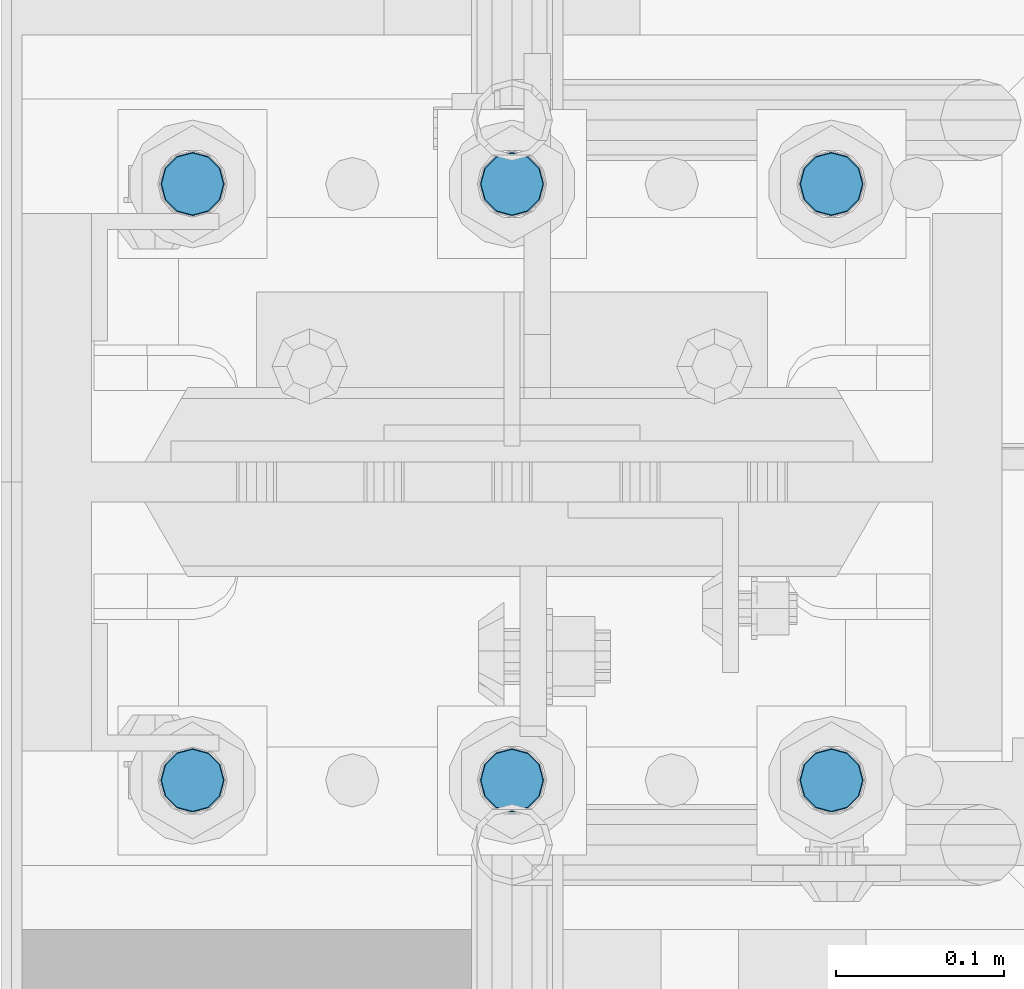
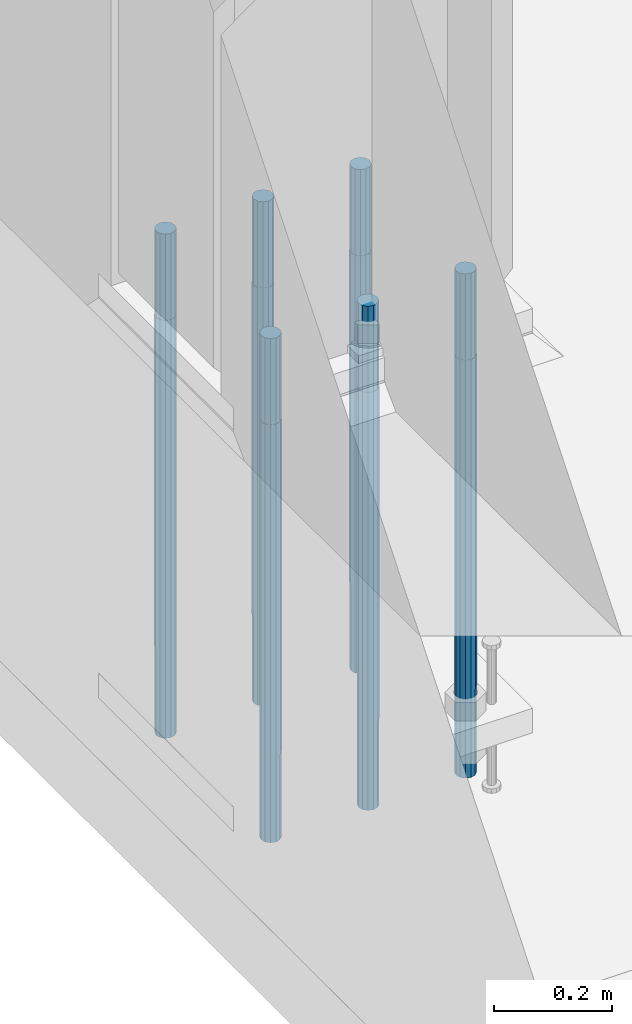
# One storey, part 599 of 1876: 6 columns, 1 element without a shape of its own.
"""IFC2X3 building model written with IfcOpenShell, lengths in millimetres."""

from ifc_helpers import new_model, si_unit, frame, origin_with_axes, place, context, subcontext, project, spatial, faceted_brep, material, type_object, element, aggregate, save


model = new_model("IFC2X3")

# Units and contexts
model_context = context("Model", 3, precision=1e-05, world=origin_with_axes())
body_context = subcontext(model_context, "Body", "Model", "MODEL_VIEW")
ifc_project = project(units=[si_unit("LENGTHUNIT", "METRE", prefix="MILLI"), si_unit("AREAUNIT", "SQUARE_METRE"), si_unit("VOLUMEUNIT", "CUBIC_METRE"), si_unit("MASSUNIT", "GRAM", prefix="KILO"), si_unit("TIMEUNIT", "SECOND"), si_unit("PLANEANGLEUNIT", "RADIAN"), si_unit("SOLIDANGLEUNIT", "STERADIAN"), si_unit("THERMODYNAMICTEMPERATUREUNIT", "DEGREE_CELSIUS"), si_unit("LUMINOUSINTENSITYUNIT", "LUMEN")], contexts=[model_context])

# Site, building, storey
site_placement = place(None, origin_with_axes())
site = spatial("IfcSite", under=ifc_project, at=site_placement, CompositionType="ELEMENT")
building_placement = place(site_placement, origin_with_axes())
building = spatial("IfcBuilding", under=site, at=building_placement, Name="Undefined", CompositionType="ELEMENT")
storey_placement = place(building_placement, origin_with_axes())
storey = spatial("IfcBuildingStorey", under=building, at=storey_placement, Name="Undefined", CompositionType="ELEMENT", Elevation=0.0)

# Assembly, columns
assembly_placement = place(storey_placement, origin_with_axes())
assembly = element("IfcElementAssembly", 1, at=assembly_placement, inside=storey, Name="TEMPLATE", AssemblyPlace="NOTDEFINED", PredefinedType="RIGID_FRAME")
ifc_material = material(Name="STEEL/F1554-GR.105")
column_type = type_object("IfcColumnType", PredefinedType="NOTDEFINED")
column_1_placement = place(assembly_placement, frame((190.5, -4749.8, 0.0), z_axis=(1.0, 0.0, 0.0), x_axis=(0.0, 0.0, -1.0)))
column_1 = element("IfcColumn", 2, at=column_1_placement, type_object=column_type, material=ifc_material, Name="ANCHOR_BOLTS", context=body_context, shape_type="Brep", body=[
    faceted_brep([(-177.8, -16.0214699700118, 9.25), (-177.8, -9.25, 16.0214699700121), (-177.8, 0.0, 18.5), (-177.8, 9.25, 16.0214699700121), (-177.8, 16.0214699700118, 9.25), (-177.8, 18.5, 0.0), (-177.8, 16.0214699700118, -9.25), (-177.8, 9.25, -16.0214699700121), (-177.8, 0.0, -18.5), (-177.8, -9.25, -16.0214699700121), (-177.8, -16.0214699700118, -9.25), (-177.8, -18.5, 0.0), (0.0, 18.5, 0.0), (0.0, 16.0214699700118, -9.25), (0.0, 9.25, -16.0214699700121), (0.0, 0.0, -18.5), (0.0, -9.25, -16.0214699700121), (0.0, -16.0214699700118, -9.25), (0.0, -18.5, 0.0), (0.0, -16.0214699700118, 9.25), (0.0, -9.25, 16.0214699700121), (0.0, 0.0, 18.5), (0.0, 9.25, 16.0214699700121), (0.0, 16.0214699700118, 9.25), (0.0, -16.4977839420935, 9.52500000000146), (0.0, -9.52500000000009, 16.4977839420935), (0.0, 0.0, 19.0499999999993), (0.0, 9.52500000000009, 16.4977839420935), (0.0, 16.4977839420935, 9.52500000000146), (-9.09494701772928e-13, 19.05, -1.81898940354586e-12), (0.0, 16.4977839420935, -9.52500000000146), (0.0, 9.52500000000009, -16.4977839420935), (0.0, 0.0, -19.05), (0.0, -9.52500000000009, -16.4977839420935), (0.0, -16.4977839420935, -9.52500000000146), (0.0, -19.0500000000002, 0.0), (685.799999999999, -19.05, 0.0), (685.799999999999, -16.4977839420936, 9.52500000000146), (685.799999999999, -9.52499999999998, 16.4977839420935), (685.799999999999, 0.0, 19.0499999999993), (685.799999999999, 9.52499999999998, 16.4977839420935), (685.799999999999, 16.4977839420936, 9.52500000000146), (685.799999999999, 19.05, 0.0), (685.799999999999, 16.4977839420936, -9.52500000000146), (685.799999999999, 9.52500000000003, -16.4977839420935), (685.799999999999, 0.0, -19.0499999999993), (685.799999999999, -9.52499999999998, -16.4977839420935), (685.799999999999, -16.4977839420936, -9.52500000000146), (685.8, -9.25, 16.0214699700121), (685.8, 0.0, 18.5), (685.8, 9.25, 16.0214699700121), (685.8, 16.0214699700118, 9.25), (685.8, 18.5, 0.0), (685.8, 16.0214699700118, -9.25), (685.8, 9.25, -16.0214699700121), (685.8, 0.0, -18.5), (685.8, -9.25, -16.0214699700121), (685.8, -16.0214699700118, -9.25), (685.8, -18.5, 0.0), (685.8, -16.0214699700118, 9.25), (863.6, -9.25, -16.0214699700121), (863.6, 0.0, -18.5), (863.6, 9.25, -16.0214699700121), (863.6, 16.0214699700118, -9.25), (863.6, 18.5, 0.0), (863.6, 16.0214699700118, 9.25), (863.6, 9.25, 16.0214699700121), (863.6, 0.0, 18.5), (863.6, -9.25, 16.0214699700121), (863.6, -16.0214699700118, 9.25), (863.6, -18.5, 0.0), (863.6, -16.0214699700118, -9.25)], [[[0, 1, 2, 3, 4, 5, 6, 7, 8, 9, 10, 11]], [[6, 5, 12, 13]], [[7, 6, 13, 14]], [[8, 7, 14, 15]], [[9, 8, 15, 16]], [[10, 9, 16, 17]], [[11, 10, 17, 18]], [[0, 11, 18, 19]], [[1, 0, 19, 20]], [[2, 1, 20, 21]], [[3, 2, 21, 22]], [[4, 3, 22, 23]], [[5, 4, 23, 12]], [[24, 25, 26, 27, 28, 29, 30, 31, 32, 33, 34, 35], [22, 21, 20, 19, 18, 17, 16, 15, 14, 13, 12, 23]], [[24, 35, 36, 37]], [[25, 24, 37, 38]], [[26, 25, 38, 39]], [[27, 26, 39, 40]], [[28, 27, 40, 41]], [[29, 28, 41, 42]], [[30, 29, 42, 43]], [[31, 30, 43, 44]], [[32, 31, 44, 45]], [[33, 32, 45, 46]], [[34, 33, 46, 47]], [[35, 34, 47, 36]], [[46, 45, 44, 43, 42, 41, 40, 39, 38, 37, 36, 47], [48, 49, 50, 51, 52, 53, 54, 55, 56, 57, 58, 59]], [[60, 61, 62, 63, 64, 65, 66, 67, 68, 69, 70, 71]], [[68, 67, 49, 48]], [[69, 68, 48, 59]], [[70, 69, 59, 58]], [[71, 70, 58, 57]], [[60, 71, 57, 56]], [[61, 60, 56, 55]], [[62, 61, 55, 54]], [[63, 62, 54, 53]], [[64, 63, 53, 52]], [[65, 64, 52, 51]], [[66, 65, 51, 50]], [[67, 66, 50, 49]]]),
])
column_2_placement = place(assembly_placement, frame((190.5, -4394.2, 0.0), z_axis=(-1.0, 0.0, 0.0), x_axis=(0.0, 0.0, -1.0)))
column_2 = element("IfcColumn", 3, at=column_2_placement, type_object=column_type, material=ifc_material, Name="ANCHOR_BOLTS", context=body_context, shape_type="Brep", body=[
    faceted_brep([(-177.8, -16.0214699700118, 9.25), (-177.8, -9.25, 16.0214699700121), (-177.8, 0.0, 18.5), (-177.8, 9.25, 16.0214699700121), (-177.8, 16.0214699700118, 9.25), (-177.8, 18.5, 0.0), (-177.8, 16.0214699700118, -9.25), (-177.8, 9.25, -16.0214699700121), (-177.8, 0.0, -18.5), (-177.8, -9.25, -16.0214699700121), (-177.8, -16.0214699700118, -9.25), (-177.8, -18.5, 0.0), (0.0, 18.5, 0.0), (0.0, 16.0214699700118, -9.25), (0.0, 9.25, -16.0214699700121), (0.0, 0.0, -18.5), (0.0, -9.25, -16.0214699700121), (0.0, -16.0214699700118, -9.25), (0.0, -18.5, 0.0), (0.0, -16.0214699700118, 9.25), (0.0, -9.25, 16.0214699700121), (0.0, 0.0, 18.5), (0.0, 9.25, 16.0214699700121), (0.0, 16.0214699700118, 9.25), (0.0, -16.4977839420935, 9.52500000000146), (0.0, -9.52500000000009, 16.4977839420935), (0.0, 0.0, 19.0499999999993), (0.0, 9.52500000000009, 16.4977839420935), (0.0, 16.4977839420935, 9.52500000000146), (-9.09494701772928e-13, 19.05, -1.81898940354586e-12), (0.0, 16.4977839420935, -9.52500000000146), (0.0, 9.52500000000009, -16.4977839420935), (0.0, 0.0, -19.05), (0.0, -9.52500000000009, -16.4977839420935), (0.0, -16.4977839420935, -9.52500000000146), (0.0, -19.0500000000002, 0.0), (685.799999999999, -19.05, 0.0), (685.799999999999, -16.4977839420936, 9.52500000000146), (685.799999999999, -9.52499999999998, 16.4977839420935), (685.799999999999, 0.0, 19.0499999999993), (685.799999999999, 9.52499999999998, 16.4977839420935), (685.799999999999, 16.4977839420936, 9.52500000000146), (685.799999999999, 19.05, 0.0), (685.799999999999, 16.4977839420936, -9.52500000000146), (685.799999999999, 9.52500000000003, -16.4977839420935), (685.799999999999, 0.0, -19.0499999999993), (685.799999999999, -9.52499999999998, -16.4977839420935), (685.799999999999, -16.4977839420936, -9.52500000000146), (685.8, -9.25, 16.0214699700121), (685.8, 0.0, 18.5), (685.8, 9.25, 16.0214699700121), (685.8, 16.0214699700118, 9.25), (685.8, 18.5, 0.0), (685.8, 16.0214699700118, -9.25), (685.8, 9.25, -16.0214699700121), (685.8, 0.0, -18.5), (685.8, -9.25, -16.0214699700121), (685.8, -16.0214699700118, -9.25), (685.8, -18.5, 0.0), (685.8, -16.0214699700118, 9.25), (863.6, -9.25, -16.0214699700121), (863.6, 0.0, -18.5), (863.6, 9.25, -16.0214699700121), (863.6, 16.0214699700118, -9.25), (863.6, 18.5, 0.0), (863.6, 16.0214699700118, 9.25), (863.6, 9.25, 16.0214699700121), (863.6, 0.0, 18.5), (863.6, -9.25, 16.0214699700121), (863.6, -16.0214699700118, 9.25), (863.6, -18.5, 0.0), (863.6, -16.0214699700118, -9.25)], [[[0, 1, 2, 3, 4, 5, 6, 7, 8, 9, 10, 11]], [[6, 5, 12, 13]], [[7, 6, 13, 14]], [[8, 7, 14, 15]], [[9, 8, 15, 16]], [[10, 9, 16, 17]], [[11, 10, 17, 18]], [[0, 11, 18, 19]], [[1, 0, 19, 20]], [[2, 1, 20, 21]], [[3, 2, 21, 22]], [[4, 3, 22, 23]], [[5, 4, 23, 12]], [[24, 25, 26, 27, 28, 29, 30, 31, 32, 33, 34, 35], [22, 21, 20, 19, 18, 17, 16, 15, 14, 13, 12, 23]], [[24, 35, 36, 37]], [[25, 24, 37, 38]], [[26, 25, 38, 39]], [[27, 26, 39, 40]], [[28, 27, 40, 41]], [[29, 28, 41, 42]], [[30, 29, 42, 43]], [[31, 30, 43, 44]], [[32, 31, 44, 45]], [[33, 32, 45, 46]], [[34, 33, 46, 47]], [[35, 34, 47, 36]], [[46, 45, 44, 43, 42, 41, 40, 39, 38, 37, 36, 47], [48, 49, 50, 51, 52, 53, 54, 55, 56, 57, 58, 59]], [[60, 61, 62, 63, 64, 65, 66, 67, 68, 69, 70, 71]], [[68, 67, 49, 48]], [[69, 68, 48, 59]], [[70, 69, 59, 58]], [[71, 70, 58, 57]], [[60, 71, 57, 56]], [[61, 60, 56, 55]], [[62, 61, 55, 54]], [[63, 62, 54, 53]], [[64, 63, 53, 52]], [[65, 64, 52, 51]], [[66, 65, 51, 50]], [[67, 66, 50, 49]]]),
])
column_3_placement = place(assembly_placement, frame((-2.8421709430404e-14, -4749.8, 0.0), z_axis=(1.0, 0.0, 0.0), x_axis=(0.0, 0.0, -1.0)))
column_3 = element("IfcColumn", 4, at=column_3_placement, type_object=column_type, material=ifc_material, Name="ANCHOR_BOLTS", context=body_context, shape_type="Brep", body=[
    faceted_brep([(-177.8, -16.0214699700118, 9.25), (-177.8, -9.25, 16.0214699700121), (-177.8, 0.0, 18.5), (-177.8, 9.25, 16.0214699700121), (-177.8, 16.0214699700118, 9.25), (-177.8, 18.5, 0.0), (-177.8, 16.0214699700118, -9.25), (-177.8, 9.25, -16.0214699700121), (-177.8, 0.0, -18.5), (-177.8, -9.25, -16.0214699700121), (-177.8, -16.0214699700118, -9.25), (-177.8, -18.5, 0.0), (0.0, 18.5, 0.0), (0.0, 16.0214699700118, -9.25), (0.0, 9.25, -16.0214699700121), (0.0, 0.0, -18.5), (0.0, -9.25, -16.0214699700121), (0.0, -16.0214699700118, -9.25), (0.0, -18.5, 0.0), (0.0, -16.0214699700118, 9.25), (0.0, -9.25, 16.0214699700121), (0.0, 0.0, 18.5), (0.0, 9.25, 16.0214699700121), (0.0, 16.0214699700118, 9.25), (0.0, -16.4977839420935, 9.52500000000146), (0.0, -9.52500000000009, 16.4977839420935), (0.0, 0.0, 19.0499999999993), (0.0, 9.52500000000009, 16.4977839420935), (0.0, 16.4977839420935, 9.52500000000146), (-9.09494701772928e-13, 19.05, -1.81898940354586e-12), (0.0, 16.4977839420935, -9.52500000000146), (0.0, 9.52500000000009, -16.4977839420935), (0.0, 0.0, -19.05), (0.0, -9.52500000000009, -16.4977839420935), (0.0, -16.4977839420935, -9.52500000000146), (0.0, -19.0500000000002, 0.0), (685.799999999999, -19.05, 0.0), (685.799999999999, -16.4977839420936, 9.52500000000146), (685.799999999999, -9.52499999999998, 16.4977839420935), (685.799999999999, 0.0, 19.0499999999993), (685.799999999999, 9.52499999999998, 16.4977839420935), (685.799999999999, 16.4977839420936, 9.52500000000146), (685.799999999999, 19.05, 0.0), (685.799999999999, 16.4977839420936, -9.52500000000146), (685.799999999999, 9.52500000000003, -16.4977839420935), (685.799999999999, 0.0, -19.0499999999993), (685.799999999999, -9.52499999999998, -16.4977839420935), (685.799999999999, -16.4977839420936, -9.52500000000146), (685.8, -9.25, 16.0214699700121), (685.8, 0.0, 18.5), (685.8, 9.25, 16.0214699700121), (685.8, 16.0214699700118, 9.25), (685.8, 18.5, 0.0), (685.8, 16.0214699700118, -9.25), (685.8, 9.25, -16.0214699700121), (685.8, 0.0, -18.5), (685.8, -9.25, -16.0214699700121), (685.8, -16.0214699700118, -9.25), (685.8, -18.5, 0.0), (685.8, -16.0214699700118, 9.25), (863.6, -9.25, -16.0214699700121), (863.6, 0.0, -18.5), (863.6, 9.25, -16.0214699700121), (863.6, 16.0214699700118, -9.25), (863.6, 18.5, 0.0), (863.6, 16.0214699700118, 9.25), (863.6, 9.25, 16.0214699700121), (863.6, 0.0, 18.5), (863.6, -9.25, 16.0214699700121), (863.6, -16.0214699700118, 9.25), (863.6, -18.5, 0.0), (863.6, -16.0214699700118, -9.25)], [[[0, 1, 2, 3, 4, 5, 6, 7, 8, 9, 10, 11]], [[6, 5, 12, 13]], [[7, 6, 13, 14]], [[8, 7, 14, 15]], [[9, 8, 15, 16]], [[10, 9, 16, 17]], [[11, 10, 17, 18]], [[0, 11, 18, 19]], [[1, 0, 19, 20]], [[2, 1, 20, 21]], [[3, 2, 21, 22]], [[4, 3, 22, 23]], [[5, 4, 23, 12]], [[24, 25, 26, 27, 28, 29, 30, 31, 32, 33, 34, 35], [22, 21, 20, 19, 18, 17, 16, 15, 14, 13, 12, 23]], [[24, 35, 36, 37]], [[25, 24, 37, 38]], [[26, 25, 38, 39]], [[27, 26, 39, 40]], [[28, 27, 40, 41]], [[29, 28, 41, 42]], [[30, 29, 42, 43]], [[31, 30, 43, 44]], [[32, 31, 44, 45]], [[33, 32, 45, 46]], [[34, 33, 46, 47]], [[35, 34, 47, 36]], [[46, 45, 44, 43, 42, 41, 40, 39, 38, 37, 36, 47], [48, 49, 50, 51, 52, 53, 54, 55, 56, 57, 58, 59]], [[60, 61, 62, 63, 64, 65, 66, 67, 68, 69, 70, 71]], [[68, 67, 49, 48]], [[69, 68, 48, 59]], [[70, 69, 59, 58]], [[71, 70, 58, 57]], [[60, 71, 57, 56]], [[61, 60, 56, 55]], [[62, 61, 55, 54]], [[63, 62, 54, 53]], [[64, 63, 53, 52]], [[65, 64, 52, 51]], [[66, 65, 51, 50]], [[67, 66, 50, 49]]]),
])
column_4_placement = place(assembly_placement, frame((-2.8421709430404e-14, -4394.2, 0.0), z_axis=(-1.0, 0.0, 0.0), x_axis=(0.0, 0.0, -1.0)))
column_4 = element("IfcColumn", 5, at=column_4_placement, type_object=column_type, material=ifc_material, Name="ANCHOR_BOLTS", context=body_context, shape_type="Brep", body=[
    faceted_brep([(-177.8, -16.0214699700118, 9.25), (-177.8, -9.25, 16.0214699700121), (-177.8, 0.0, 18.5), (-177.8, 9.25, 16.0214699700121), (-177.8, 16.0214699700118, 9.25), (-177.8, 18.5, 0.0), (-177.8, 16.0214699700118, -9.25), (-177.8, 9.25, -16.0214699700121), (-177.8, 0.0, -18.5), (-177.8, -9.25, -16.0214699700121), (-177.8, -16.0214699700118, -9.25), (-177.8, -18.5, 0.0), (0.0, 18.5, 0.0), (0.0, 16.0214699700118, -9.25), (0.0, 9.25, -16.0214699700121), (0.0, 0.0, -18.5), (0.0, -9.25, -16.0214699700121), (0.0, -16.0214699700118, -9.25), (0.0, -18.5, 0.0), (0.0, -16.0214699700118, 9.25), (0.0, -9.25, 16.0214699700121), (0.0, 0.0, 18.5), (0.0, 9.25, 16.0214699700121), (0.0, 16.0214699700118, 9.25), (0.0, -16.4977839420935, 9.52500000000146), (0.0, -9.52500000000009, 16.4977839420935), (0.0, 0.0, 19.0499999999993), (0.0, 9.52500000000009, 16.4977839420935), (0.0, 16.4977839420935, 9.52500000000146), (-9.09494701772928e-13, 19.05, -1.81898940354586e-12), (0.0, 16.4977839420935, -9.52500000000146), (0.0, 9.52500000000009, -16.4977839420935), (0.0, 0.0, -19.05), (0.0, -9.52500000000009, -16.4977839420935), (0.0, -16.4977839420935, -9.52500000000146), (0.0, -19.0500000000002, 0.0), (685.799999999999, -19.05, 0.0), (685.799999999999, -16.4977839420936, 9.52500000000146), (685.799999999999, -9.52499999999998, 16.4977839420935), (685.799999999999, 0.0, 19.0499999999993), (685.799999999999, 9.52499999999998, 16.4977839420935), (685.799999999999, 16.4977839420936, 9.52500000000146), (685.799999999999, 19.05, 0.0), (685.799999999999, 16.4977839420936, -9.52500000000146), (685.799999999999, 9.52500000000003, -16.4977839420935), (685.799999999999, 0.0, -19.0499999999993), (685.799999999999, -9.52499999999998, -16.4977839420935), (685.799999999999, -16.4977839420936, -9.52500000000146), (685.8, -9.25, 16.0214699700121), (685.8, 0.0, 18.5), (685.8, 9.25, 16.0214699700121), (685.8, 16.0214699700118, 9.25), (685.8, 18.5, 0.0), (685.8, 16.0214699700118, -9.25), (685.8, 9.25, -16.0214699700121), (685.8, 0.0, -18.5), (685.8, -9.25, -16.0214699700121), (685.8, -16.0214699700118, -9.25), (685.8, -18.5, 0.0), (685.8, -16.0214699700118, 9.25), (863.6, -9.25, -16.0214699700121), (863.6, 0.0, -18.5), (863.6, 9.25, -16.0214699700121), (863.6, 16.0214699700118, -9.25), (863.6, 18.5, 0.0), (863.6, 16.0214699700118, 9.25), (863.6, 9.25, 16.0214699700121), (863.6, 0.0, 18.5), (863.6, -9.25, 16.0214699700121), (863.6, -16.0214699700118, 9.25), (863.6, -18.5, 0.0), (863.6, -16.0214699700118, -9.25)], [[[0, 1, 2, 3, 4, 5, 6, 7, 8, 9, 10, 11]], [[6, 5, 12, 13]], [[7, 6, 13, 14]], [[8, 7, 14, 15]], [[9, 8, 15, 16]], [[10, 9, 16, 17]], [[11, 10, 17, 18]], [[0, 11, 18, 19]], [[1, 0, 19, 20]], [[2, 1, 20, 21]], [[3, 2, 21, 22]], [[4, 3, 22, 23]], [[5, 4, 23, 12]], [[24, 25, 26, 27, 28, 29, 30, 31, 32, 33, 34, 35], [22, 21, 20, 19, 18, 17, 16, 15, 14, 13, 12, 23]], [[24, 35, 36, 37]], [[25, 24, 37, 38]], [[26, 25, 38, 39]], [[27, 26, 39, 40]], [[28, 27, 40, 41]], [[29, 28, 41, 42]], [[30, 29, 42, 43]], [[31, 30, 43, 44]], [[32, 31, 44, 45]], [[33, 32, 45, 46]], [[34, 33, 46, 47]], [[35, 34, 47, 36]], [[46, 45, 44, 43, 42, 41, 40, 39, 38, 37, 36, 47], [48, 49, 50, 51, 52, 53, 54, 55, 56, 57, 58, 59]], [[60, 61, 62, 63, 64, 65, 66, 67, 68, 69, 70, 71]], [[68, 67, 49, 48]], [[69, 68, 48, 59]], [[70, 69, 59, 58]], [[71, 70, 58, 57]], [[60, 71, 57, 56]], [[61, 60, 56, 55]], [[62, 61, 55, 54]], [[63, 62, 54, 53]], [[64, 63, 53, 52]], [[65, 64, 52, 51]], [[66, 65, 51, 50]], [[67, 66, 50, 49]]]),
])
column_5_placement = place(assembly_placement, frame((-190.5, -4749.8, 0.0), z_axis=(1.0, 0.0, 0.0), x_axis=(0.0, 0.0, -1.0)))
column_5 = element("IfcColumn", 6, at=column_5_placement, type_object=column_type, material=ifc_material, Name="ANCHOR_BOLTS", context=body_context, shape_type="Brep", body=[
    faceted_brep([(-177.8, -16.0214699700118, 9.25), (-177.8, -9.25, 16.0214699700121), (-177.8, 0.0, 18.5), (-177.8, 9.25, 16.0214699700121), (-177.8, 16.0214699700118, 9.25), (-177.8, 18.5, 0.0), (-177.8, 16.0214699700118, -9.25), (-177.8, 9.25, -16.0214699700121), (-177.8, 0.0, -18.5), (-177.8, -9.25, -16.0214699700121), (-177.8, -16.0214699700118, -9.25), (-177.8, -18.5, 0.0), (0.0, 18.5, 0.0), (0.0, 16.0214699700118, -9.25), (0.0, 9.25, -16.0214699700121), (0.0, 0.0, -18.5), (0.0, -9.25, -16.0214699700121), (0.0, -16.0214699700118, -9.25), (0.0, -18.5, 0.0), (0.0, -16.0214699700118, 9.25), (0.0, -9.25, 16.0214699700121), (0.0, 0.0, 18.5), (0.0, 9.25, 16.0214699700121), (0.0, 16.0214699700118, 9.25), (0.0, -16.4977839420935, 9.52500000000146), (0.0, -9.52500000000009, 16.4977839420935), (0.0, 0.0, 19.0499999999993), (0.0, 9.52500000000009, 16.4977839420935), (0.0, 16.4977839420935, 9.52500000000146), (-9.09494701772928e-13, 19.05, -1.81898940354586e-12), (0.0, 16.4977839420935, -9.52500000000146), (0.0, 9.52500000000009, -16.4977839420935), (0.0, 0.0, -19.05), (0.0, -9.52500000000009, -16.4977839420935), (0.0, -16.4977839420935, -9.52500000000146), (0.0, -19.0500000000002, 0.0), (685.799999999999, -19.05, 0.0), (685.799999999999, -16.4977839420936, 9.52500000000146), (685.799999999999, -9.52499999999998, 16.4977839420935), (685.799999999999, 0.0, 19.0499999999993), (685.799999999999, 9.52499999999998, 16.4977839420935), (685.799999999999, 16.4977839420936, 9.52500000000146), (685.799999999999, 19.05, 0.0), (685.799999999999, 16.4977839420936, -9.52500000000146), (685.799999999999, 9.52500000000003, -16.4977839420935), (685.799999999999, 0.0, -19.0499999999993), (685.799999999999, -9.52499999999998, -16.4977839420935), (685.799999999999, -16.4977839420936, -9.52500000000146), (685.8, -9.25, 16.0214699700121), (685.8, 0.0, 18.5), (685.8, 9.25, 16.0214699700121), (685.8, 16.0214699700118, 9.25), (685.8, 18.5, 0.0), (685.8, 16.0214699700118, -9.25), (685.8, 9.25, -16.0214699700121), (685.8, 0.0, -18.5), (685.8, -9.25, -16.0214699700121), (685.8, -16.0214699700118, -9.25), (685.8, -18.5, 0.0), (685.8, -16.0214699700118, 9.25), (863.6, -9.25, -16.0214699700121), (863.6, 0.0, -18.5), (863.6, 9.25, -16.0214699700121), (863.6, 16.0214699700118, -9.25), (863.6, 18.5, 0.0), (863.6, 16.0214699700118, 9.25), (863.6, 9.25, 16.0214699700121), (863.6, 0.0, 18.5), (863.6, -9.25, 16.0214699700121), (863.6, -16.0214699700118, 9.25), (863.6, -18.5, 0.0), (863.6, -16.0214699700118, -9.25)], [[[0, 1, 2, 3, 4, 5, 6, 7, 8, 9, 10, 11]], [[6, 5, 12, 13]], [[7, 6, 13, 14]], [[8, 7, 14, 15]], [[9, 8, 15, 16]], [[10, 9, 16, 17]], [[11, 10, 17, 18]], [[0, 11, 18, 19]], [[1, 0, 19, 20]], [[2, 1, 20, 21]], [[3, 2, 21, 22]], [[4, 3, 22, 23]], [[5, 4, 23, 12]], [[24, 25, 26, 27, 28, 29, 30, 31, 32, 33, 34, 35], [22, 21, 20, 19, 18, 17, 16, 15, 14, 13, 12, 23]], [[24, 35, 36, 37]], [[25, 24, 37, 38]], [[26, 25, 38, 39]], [[27, 26, 39, 40]], [[28, 27, 40, 41]], [[29, 28, 41, 42]], [[30, 29, 42, 43]], [[31, 30, 43, 44]], [[32, 31, 44, 45]], [[33, 32, 45, 46]], [[34, 33, 46, 47]], [[35, 34, 47, 36]], [[46, 45, 44, 43, 42, 41, 40, 39, 38, 37, 36, 47], [48, 49, 50, 51, 52, 53, 54, 55, 56, 57, 58, 59]], [[60, 61, 62, 63, 64, 65, 66, 67, 68, 69, 70, 71]], [[68, 67, 49, 48]], [[69, 68, 48, 59]], [[70, 69, 59, 58]], [[71, 70, 58, 57]], [[60, 71, 57, 56]], [[61, 60, 56, 55]], [[62, 61, 55, 54]], [[63, 62, 54, 53]], [[64, 63, 53, 52]], [[65, 64, 52, 51]], [[66, 65, 51, 50]], [[67, 66, 50, 49]]]),
])
column_6_placement = place(assembly_placement, frame((-190.5, -4394.2, 0.0), z_axis=(-1.0, 0.0, 0.0), x_axis=(0.0, 0.0, -1.0)))
column_6 = element("IfcColumn", 7, at=column_6_placement, type_object=column_type, material=ifc_material, Name="ANCHOR_BOLTS", context=body_context, shape_type="Brep", body=[
    faceted_brep([(-177.8, -16.0214699700118, 9.25), (-177.8, -9.25, 16.0214699700121), (-177.8, 0.0, 18.5), (-177.8, 9.25, 16.0214699700121), (-177.8, 16.0214699700118, 9.25), (-177.8, 18.5, 0.0), (-177.8, 16.0214699700118, -9.25), (-177.8, 9.25, -16.0214699700121), (-177.8, 0.0, -18.5), (-177.8, -9.25, -16.0214699700121), (-177.8, -16.0214699700118, -9.25), (-177.8, -18.5, 0.0), (0.0, 18.5, 0.0), (0.0, 16.0214699700118, -9.25), (0.0, 9.25, -16.0214699700121), (0.0, 0.0, -18.5), (0.0, -9.25, -16.0214699700121), (0.0, -16.0214699700118, -9.25), (0.0, -18.5, 0.0), (0.0, -16.0214699700118, 9.25), (0.0, -9.25, 16.0214699700121), (0.0, 0.0, 18.5), (0.0, 9.25, 16.0214699700121), (0.0, 16.0214699700118, 9.25), (0.0, -16.4977839420935, 9.52500000000146), (0.0, -9.52500000000009, 16.4977839420935), (0.0, 0.0, 19.0499999999993), (0.0, 9.52500000000009, 16.4977839420935), (0.0, 16.4977839420935, 9.52500000000146), (-9.09494701772928e-13, 19.05, -1.81898940354586e-12), (0.0, 16.4977839420935, -9.52500000000146), (0.0, 9.52500000000009, -16.4977839420935), (0.0, 0.0, -19.05), (0.0, -9.52500000000009, -16.4977839420935), (0.0, -16.4977839420935, -9.52500000000146), (0.0, -19.0500000000002, 0.0), (685.799999999999, -19.05, 0.0), (685.799999999999, -16.4977839420936, 9.52500000000146), (685.799999999999, -9.52499999999998, 16.4977839420935), (685.799999999999, 0.0, 19.0499999999993), (685.799999999999, 9.52499999999998, 16.4977839420935), (685.799999999999, 16.4977839420936, 9.52500000000146), (685.799999999999, 19.05, 0.0), (685.799999999999, 16.4977839420936, -9.52500000000146), (685.799999999999, 9.52500000000003, -16.4977839420935), (685.799999999999, 0.0, -19.0499999999993), (685.799999999999, -9.52499999999998, -16.4977839420935), (685.799999999999, -16.4977839420936, -9.52500000000146), (685.8, -9.25, 16.0214699700121), (685.8, 0.0, 18.5), (685.8, 9.25, 16.0214699700121), (685.8, 16.0214699700118, 9.25), (685.8, 18.5, 0.0), (685.8, 16.0214699700118, -9.25), (685.8, 9.25, -16.0214699700121), (685.8, 0.0, -18.5), (685.8, -9.25, -16.0214699700121), (685.8, -16.0214699700118, -9.25), (685.8, -18.5, 0.0), (685.8, -16.0214699700118, 9.25), (863.6, -9.25, -16.0214699700121), (863.6, 0.0, -18.5), (863.6, 9.25, -16.0214699700121), (863.6, 16.0214699700118, -9.25), (863.6, 18.5, 0.0), (863.6, 16.0214699700118, 9.25), (863.6, 9.25, 16.0214699700121), (863.6, 0.0, 18.5), (863.6, -9.25, 16.0214699700121), (863.6, -16.0214699700118, 9.25), (863.6, -18.5, 0.0), (863.6, -16.0214699700118, -9.25)], [[[0, 1, 2, 3, 4, 5, 6, 7, 8, 9, 10, 11]], [[6, 5, 12, 13]], [[7, 6, 13, 14]], [[8, 7, 14, 15]], [[9, 8, 15, 16]], [[10, 9, 16, 17]], [[11, 10, 17, 18]], [[0, 11, 18, 19]], [[1, 0, 19, 20]], [[2, 1, 20, 21]], [[3, 2, 21, 22]], [[4, 3, 22, 23]], [[5, 4, 23, 12]], [[24, 25, 26, 27, 28, 29, 30, 31, 32, 33, 34, 35], [22, 21, 20, 19, 18, 17, 16, 15, 14, 13, 12, 23]], [[24, 35, 36, 37]], [[25, 24, 37, 38]], [[26, 25, 38, 39]], [[27, 26, 39, 40]], [[28, 27, 40, 41]], [[29, 28, 41, 42]], [[30, 29, 42, 43]], [[31, 30, 43, 44]], [[32, 31, 44, 45]], [[33, 32, 45, 46]], [[34, 33, 46, 47]], [[35, 34, 47, 36]], [[46, 45, 44, 43, 42, 41, 40, 39, 38, 37, 36, 47], [48, 49, 50, 51, 52, 53, 54, 55, 56, 57, 58, 59]], [[60, 61, 62, 63, 64, 65, 66, 67, 68, 69, 70, 71]], [[68, 67, 49, 48]], [[69, 68, 48, 59]], [[70, 69, 59, 58]], [[71, 70, 58, 57]], [[60, 71, 57, 56]], [[61, 60, 56, 55]], [[62, 61, 55, 54]], [[63, 62, 54, 53]], [[64, 63, 53, 52]], [[65, 64, 52, 51]], [[66, 65, 51, 50]], [[67, 66, 50, 49]]]),
])
aggregate(assembly, [column_1, column_2, column_3, column_4, column_5, column_6])

save(model, "model.ifc")
